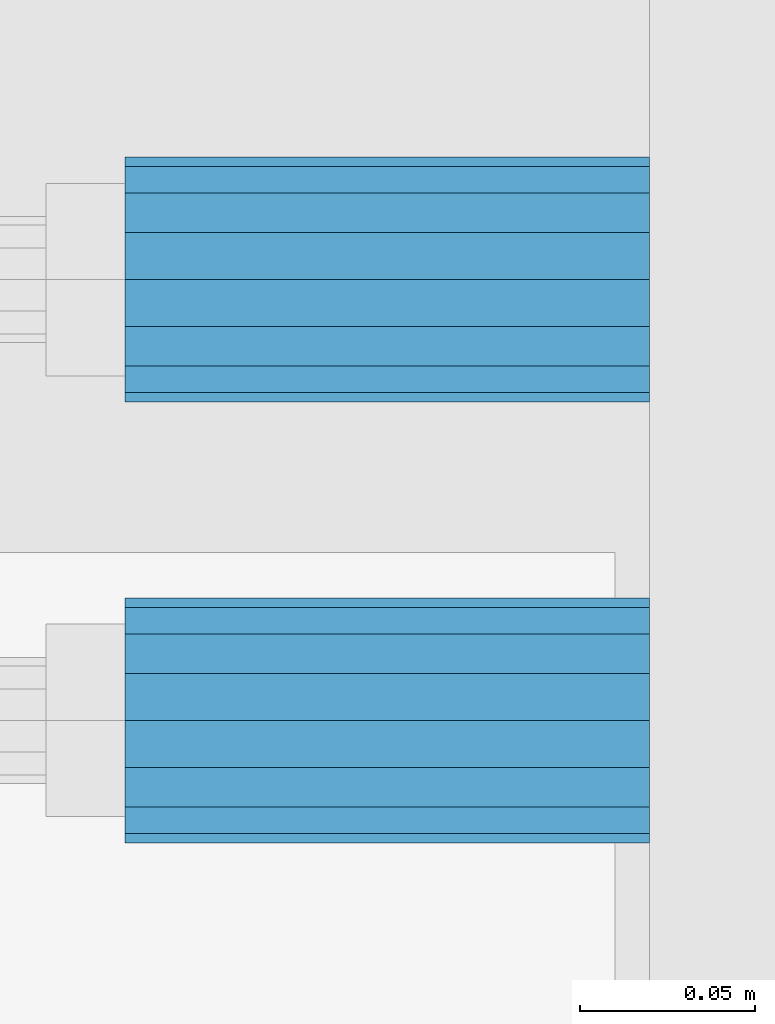
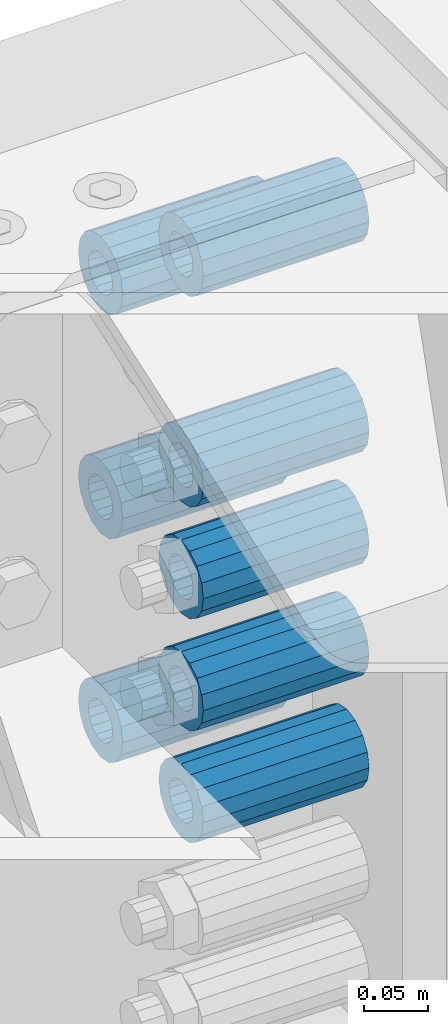
# One storey, part 171 of 242: 8 beams.
"""IFC2X3 building model written with IfcOpenShell, lengths in millimetres."""

import ifcopenshell
import ifcopenshell.guid

model = None  # the IFC model being written
_history = None  # IfcOwnerHistory: only IFC2X3 demands one
_inside = {}  # id of a spatial element -> (the spatial element, [elements in it])
_under = {}  # id of a project, library or spatial element -> (it, [spatial elements below it])
_declared = {}  # id of a project -> (the project, [libraries it declares])
_typed = {}  # id of a type object -> (the type object, [elements of that type])
_made_of = {}  # id of a material, layer set ... -> (it, [elements and type objects made of it])


def new_model(schema):
    """Start an empty IFC model of exactly this schema.

    Asked for "IFC4X3", IfcOpenShell would pick the latest addendum, in which some entities
    have other attributes; the version numbers below select the first issue.
    IFC2X3 requires an IfcOwnerHistory on every rooted entity: one is made here for all.
    """
    global model, _history
    if schema == "IFC4X3":
        model = ifcopenshell.file(schema_version=(4, 3, 0, 0))
    else:
        model = ifcopenshell.file(schema=schema)
    _inside.clear()
    _under.clear()
    _declared.clear()
    _typed.clear()
    _made_of.clear()
    _history = None
    if model.schema == "IFC2X3":
        org = make("IfcOrganization", Name="unknown")
        user = make(
            "IfcPersonAndOrganization",
            ThePerson=make("IfcPerson", FamilyName="unknown"),
            TheOrganization=org,
        )
        app = make(
            "IfcApplication",
            ApplicationDeveloper=org,
            Version="unknown",
            ApplicationFullName="unknown",
            ApplicationIdentifier="unknown",
        )
        _history = make(
            "IfcOwnerHistory",
            OwningUser=user,
            OwningApplication=app,
            ChangeAction="ADDED",
            CreationDate=0,
        )
    return model


def make(cls, **values):
    """One entity of the class cls with the attributes given. An attribute that is None is left unset."""
    return model.create_entity(
        cls, **{name: value for name, value in values.items() if value is not None}
    )


def rooted(cls, **values):
    """An entity with a GlobalId (a new one), such as an element, a storey or a relation."""
    return make(cls, GlobalId=ifcopenshell.guid.new(), OwnerHistory=_history, **values)


def si_unit(unit_type, name, prefix=None):
    """IfcSIUnit, for example si_unit("LENGTHUNIT", "METRE", prefix="MILLI")."""
    return make("IfcSIUnit", UnitType=unit_type, Prefix=prefix, Name=name)


def assignment(units):
    """IfcUnitAssignment: the units of a project."""
    return None if units is None else make("IfcUnitAssignment", Units=units)


def point(xyz):
    """IfcCartesianPoint."""
    return None if xyz is None else make("IfcCartesianPoint", Coordinates=xyz)


def direction(xyz):
    """IfcDirection."""
    return None if xyz is None else make("IfcDirection", DirectionRatios=xyz)


def frame(location, z_axis=None, x_axis=None):
    """IfcAxis2Placement3D, a coordinate frame: its origin and axes. An axis left out is left unset."""
    return make(
        "IfcAxis2Placement3D",
        Location=point(location),
        Axis=direction(z_axis),
        RefDirection=direction(x_axis),
    )


def origin_with_axes():
    """The frame at (0, 0, 0) with the z axis (0, 0, 1) and the x axis (1, 0, 0) written out."""
    return frame((0.0, 0.0, 0.0), z_axis=(0.0, 0.0, 1.0), x_axis=(1.0, 0.0, 0.0))


def place(relative_to, where):
    """IfcLocalPlacement: puts the frame where relative to a parent placement (None: the world)."""
    return make(
        "IfcLocalPlacement", PlacementRelTo=relative_to, RelativePlacement=where
    )


def context(
    kind, dimensions, precision=None, world=None, true_north=None, identifier=None
):
    """IfcGeometricRepresentationContext, for example the 3D "Model" context."""
    return make(
        "IfcGeometricRepresentationContext",
        ContextIdentifier=identifier,
        ContextType=kind,
        CoordinateSpaceDimension=dimensions,
        Precision=precision,
        WorldCoordinateSystem=world,
        TrueNorth=true_north,
    )


def subcontext(parent, identifier, kind, view, scale=None):
    """IfcGeometricRepresentationSubContext, for example "Body" below "Model"."""
    return make(
        "IfcGeometricRepresentationSubContext",
        ContextIdentifier=identifier,
        ContextType=kind,
        ParentContext=parent,
        TargetScale=scale,
        TargetView=view,
    )


def project(units=None, contexts=None):
    """IfcProject with its units and contexts."""
    return rooted(
        "IfcProject",
        Name="project",
        RepresentationContexts=contexts,
        UnitsInContext=assignment(units),
    )


def spatial(cls, under=None, at=None, **own):
    """A site, building, storey or space (cls), placed at a placement, below another one or the project."""
    s = rooted(cls, ObjectPlacement=at, **own)
    if under is not None:
        _under.setdefault(under.id(), (under, []))[1].append(s)
    return s


def faces_of(points, faces, orient=None, outer=None):
    """IfcFace entities. A face is a list of loops; a loop is a list of indices into points, from 0.

    orient and outer hold one flag for each loop. By default every Orientation is true, the
    first loop of a face is its IfcFaceOuterBound and the others are IfcFaceBound.
    """
    made = []
    for i, loops in enumerate(faces):
        bounds = []
        for j, loop in enumerate(loops):
            is_outer = j == 0 if outer is None else outer[i][j]
            bounds.append(
                make(
                    "IfcFaceOuterBound" if is_outer else "IfcFaceBound",
                    Bound=make("IfcPolyLoop", Polygon=[points[k] for k in loop]),
                    Orientation=True if orient is None else orient[i][j],
                )
            )
        made.append(make("IfcFace", Bounds=bounds))
    return made


def faceted_brep(points, faces, orient=None, outer=None, voids=None):
    """IfcFacetedBrep: a solid bounded by flat faces; with voids (closed shells), ...WithVoids."""
    shared = [point(p) for p in points]
    hull = make("IfcClosedShell", CfsFaces=faces_of(shared, faces, orient, outer))
    if voids is None:
        return make("IfcFacetedBrep", Outer=hull)
    return make(
        "IfcFacetedBrepWithVoids",
        Outer=hull,
        Voids=[
            make(cls, CfsFaces=faces_of(shared, fs, o, b)) for cls, fs, o, b in voids
        ],
    )


def shape(context_of_items, identifier, shape_type, items):
    """IfcShapeRepresentation: the items that make up one representation, for example the "Body"."""
    return make(
        "IfcShapeRepresentation",
        ContextOfItems=context_of_items,
        RepresentationIdentifier=identifier,
        RepresentationType=shape_type,
        Items=items,
    )


def material(Name=None, Category=None):
    """IfcMaterial."""
    return make("IfcMaterial", Name=Name, Category=Category)


def made_of(thing, what):
    """Note that an element or type object is made of a material, layer set ...; save() writes the relation."""
    if what is not None:
        _made_of.setdefault(what.id(), (what, []))[1].append(thing)
    return thing


def type_object(cls, material=None, **own):
    """A type object (cls), such as IfcWallType, which elements share."""
    return made_of(rooted(cls, **own), material)


def element(
    cls,
    number,
    at=None,
    inside=None,
    cuts=None,
    type_object=None,
    material=None,
    context=None,
    identifier="Body",
    shape_type=None,
    held_by="IfcProductDefinitionShape",
    body=None,
    shapes=None,
    **own,
):
    """One element of the class cls, such as IfcWall. Its Tag is "e" and its number.

    at: its placement. inside: the storey or other place that contains it. cuts: it is an
    opening in that element (IfcRelVoidsElement). A single representation is given by context,
    identifier, shape_type and body (its items); several are given by shapes. held_by: the class
    of the entity that holds the representations. save() writes the other relations.
    """
    e = rooted(cls, Tag="e%d" % number, ObjectPlacement=at, **own)
    if body is not None:
        shapes = [shape(context, identifier, shape_type, body)]
    if shapes is not None:
        e.Representation = make(held_by, Representations=shapes)
    if inside is not None:
        _inside.setdefault(inside.id(), (inside, []))[1].append(e)
    if cuts is not None:
        rooted(
            "IfcRelVoidsElement", RelatingBuildingElement=cuts, RelatedOpeningElement=e
        )
    if type_object is not None:
        _typed.setdefault(type_object.id(), (type_object, []))[1].append(e)
    return made_of(e, material)


def aggregate(whole, parts):
    """IfcRelAggregates: a whole, such as a stair, and the parts it consists of."""
    return rooted("IfcRelAggregates", RelatingObject=whole, RelatedObjects=parts)


def save(model, path):
    """Write the relations noted so far, then the file.

    IfcRelAggregates (storeys below a building ...), IfcRelContainedInSpatialStructure (elements
    in a storey), IfcRelDefinesByType, IfcRelAssociatesMaterial and IfcRelDeclares: one each for
    every whole, place, type object, material and project.
    """
    for whole, parts in _under.values():
        aggregate(whole, parts)
    for where, things in _inside.values():
        rooted(
            "IfcRelContainedInSpatialStructure",
            RelatedElements=things,
            RelatingStructure=where,
        )
    for kind, things in _typed.values():
        rooted("IfcRelDefinesByType", RelatedObjects=things, RelatingType=kind)
    for what, things in _made_of.values():
        rooted("IfcRelAssociatesMaterial", RelatedObjects=things, RelatingMaterial=what)
    for by, libraries in _declared.values():
        rooted("IfcRelDeclares", RelatingContext=by, RelatedDefinitions=libraries)
    model.write(path)


model = new_model("IFC2X3")

# Units and contexts
model_context = context("Model", 3, precision=1e-05, world=origin_with_axes())
body_context = subcontext(model_context, "Body", "Model", "MODEL_VIEW")
ifc_project = project(units=[si_unit("LENGTHUNIT", "METRE", prefix="MILLI"), si_unit("AREAUNIT", "SQUARE_METRE"), si_unit("VOLUMEUNIT", "CUBIC_METRE"), si_unit("MASSUNIT", "GRAM", prefix="KILO"), si_unit("TIMEUNIT", "SECOND"), si_unit("PLANEANGLEUNIT", "RADIAN"), si_unit("SOLIDANGLEUNIT", "STERADIAN"), si_unit("THERMODYNAMICTEMPERATUREUNIT", "DEGREE_CELSIUS"), si_unit("LUMINOUSINTENSITYUNIT", "LUMEN")], contexts=[model_context])

# Site, building, storey
site_placement = place(None, origin_with_axes())
site = spatial("IfcSite", under=ifc_project, at=site_placement, CompositionType="ELEMENT")
building_placement = place(site_placement, origin_with_axes())
building = spatial("IfcBuilding", under=site, at=building_placement, Name="Standard", CompositionType="ELEMENT")
storey_placement = place(building_placement, origin_with_axes())
storey = spatial("IfcBuildingStorey", under=building, at=storey_placement, Name="Undefined", CompositionType="ELEMENT", Elevation=0.0)

# Beams
ifc_material = material()
beam_type = type_object("IfcBeamType", PredefinedType="NOTDEFINED")
beam_1_placement = place(storey_placement, frame((-22210.0, -18063.0, -397.0), z_axis=(0.0, 0.0, 1.0), x_axis=(1.0, 0.0, 0.0)))
element("IfcBeam", 1, at=beam_1_placement, inside=storey, type_object=beam_type, material=ifc_material, context=body_context, shape_type="Brep", body=[
    faceted_brep([(1.33248249767348e-07, -19.0000000004493, -6.26823748461902e-09), (0.0, -17.5537111177146, 7.27098521493673), (150.0, -17.5537111177146, 7.27098521493673), (150.0, -19.0, 0.0), (0.0, -13.4350288425449, 13.4350288425444), (150.0, -13.4350288425449, 13.4350288425444), (0.0, -7.27098521493826, 17.5537111177144), (150.0, -7.27098521493826, 17.5537111177144), (-6.29370333626866e-09, -4.49290382675827e-10, 18.9999999937318), (150.0, 0.0, 19.0), (0.0, 7.27098521493826, 17.5537111177144), (150.0, 7.27098521493826, 17.5537111177144), (0.0, 13.4350288425449, 13.4350288425444), (150.0, 13.4350288425449, 13.4350288425444), (0.0, 17.5537111177146, 7.2709852149367), (150.0, 17.5537111177146, 7.2709852149367), (-1.31243723444641e-07, 18.9999999995507, -6.26823748461902e-09), (150.0, 19.0, 0.0), (0.0, 17.5537111177146, -7.2709852149367), (150.0, 17.5537111177146, -7.2709852149367), (0.0, 13.4350288425449, -13.4350288425444), (150.0, 13.4350288425449, -13.4350288425444), (0.0, 7.27098521493826, -17.5537111177144), (150.0, 7.27098521493826, -17.5537111177144), (8.2982296589762e-09, -4.49290382675827e-10, -19.0000000062719), (150.0, 0.0, -19.0), (0.0, -7.27098521493826, -17.5537111177144), (150.0, -7.27098521493826, -17.5537111177144), (0.0, -13.4350288425449, -13.4350288425444), (150.0, -13.4350288425449, -13.4350288425444), (0.0, -17.5537111177146, -7.2709852149367), (150.0, -17.5537111177146, -7.2709852149367), (-3.63797880709171e-12, -35.0, 0.0), (-3.63797880709171e-12, -32.335783637895, -13.3939201327812), (150.0, -32.3357836378964, -13.3939201327782), (150.0, -35.0, 0.0), (0.0, -24.7487373415292, -24.7487373415315), (150.0, -24.7487373415279, -24.7487373415292), (0.0, -13.3939201327782, -32.3357836378964), (150.0, -13.3939201327776, -32.335783637895), (0.0, 0.0, -35.0000000000036), (150.0, 0.0, -35.0), (0.0, 13.3939201327782, -32.3357836378964), (150.0, 13.3939201327776, -32.335783637895), (0.0, 24.7487373415292, -24.7487373415315), (150.0, 24.7487373415279, -24.7487373415292), (-3.63797880709171e-12, 32.335783637895, -13.3939201327812), (150.0, 32.3357836378964, -13.3939201327781), (-3.63797880709171e-12, 35.0, 0.0), (150.0, 35.0, 0.0), (-7.27595761418343e-12, 32.335783637895, 13.3939201327739), (150.0, 32.3357836378964, 13.3939201327781), (-7.27595761418343e-12, 24.7487373415292, 24.7487373415242), (150.0, 24.7487373415279, 24.7487373415292), (-7.27595761418343e-12, 13.3939201327781, 32.3357836378891), (150.0, 13.3939201327776, 32.335783637895), (-1.09139364212751e-11, 0.0, 34.9999999999964), (150.0, 0.0, 35.0), (-7.27595761418343e-12, -13.3939201327781, 32.3357836378891), (150.0, -13.3939201327776, 32.335783637895), (-7.27595761418343e-12, -24.7487373415292, 24.7487373415242), (150.0, -24.7487373415279, 24.7487373415292), (-7.27595761418343e-12, -32.335783637895, 13.3939201327739), (150.0, -32.3357836378964, 13.3939201327781)], [[[0, 1, 2, 3]], [[1, 4, 5, 2]], [[4, 6, 7, 5]], [[6, 8, 9, 7]], [[8, 10, 11, 9]], [[10, 12, 13, 11]], [[12, 14, 15, 13]], [[14, 16, 17, 15]], [[16, 18, 19, 17]], [[18, 20, 21, 19]], [[20, 22, 23, 21]], [[22, 24, 25, 23]], [[24, 26, 27, 25]], [[26, 28, 29, 27]], [[28, 30, 31, 29]], [[30, 0, 3, 31]], [[32, 33, 34, 35]], [[33, 36, 37, 34]], [[36, 38, 39, 37]], [[38, 40, 41, 39]], [[40, 42, 43, 41]], [[42, 44, 45, 43]], [[44, 46, 47, 45]], [[46, 48, 49, 47]], [[48, 50, 51, 49]], [[50, 52, 53, 51]], [[52, 54, 55, 53]], [[54, 56, 57, 55]], [[56, 58, 59, 57]], [[58, 60, 61, 59]], [[60, 62, 63, 61]], [[62, 32, 35, 63]], [[37, 39, 41, 43, 45, 47, 49, 51, 53, 55, 57, 59, 61, 63, 35, 34], [5, 7, 9, 11, 13, 15, 17, 19, 21, 23, 25, 27, 29, 31, 3, 2]], [[62, 60, 58, 56, 54, 52, 50, 48, 46, 44, 42, 40, 38, 36, 33, 32], [30, 28, 26, 24, 22, 20, 18, 16, 14, 12, 10, 8, 6, 4, 1, 0]]]),
])
beam_2_placement = place(storey_placement, frame((-22210.0, -17937.0, -611.0), z_axis=(0.0, 0.0, 1.0), x_axis=(1.0, 0.0, 0.0)))
element("IfcBeam", 2, at=beam_2_placement, inside=storey, type_object=beam_type, material=ifc_material, context=body_context, shape_type="Brep", body=[
    faceted_brep([(1.33248249767348e-07, -19.0000000004493, -6.26823748461902e-09), (0.0, -17.5537111177146, 7.27098521493673), (150.0, -17.5537111177146, 7.27098521493673), (150.0, -19.0, 0.0), (0.0, -13.4350288425449, 13.4350288425444), (150.0, -13.4350288425449, 13.4350288425444), (0.0, -7.27098521493826, 17.5537111177144), (150.0, -7.27098521493826, 17.5537111177144), (-6.29370333626866e-09, -4.49290382675827e-10, 18.9999999937318), (150.0, 0.0, 19.0), (0.0, 7.27098521493826, 17.5537111177144), (150.0, 7.27098521493826, 17.5537111177144), (0.0, 13.4350288425449, 13.4350288425444), (150.0, 13.4350288425449, 13.4350288425444), (0.0, 17.5537111177146, 7.2709852149367), (150.0, 17.5537111177146, 7.2709852149367), (-1.31243723444641e-07, 18.9999999995507, -6.26823748461902e-09), (150.0, 19.0, 0.0), (0.0, 17.5537111177146, -7.2709852149367), (150.0, 17.5537111177146, -7.2709852149367), (0.0, 13.4350288425449, -13.4350288425444), (150.0, 13.4350288425449, -13.4350288425444), (0.0, 7.27098521493826, -17.5537111177144), (150.0, 7.27098521493826, -17.5537111177144), (8.2982296589762e-09, -4.49290382675827e-10, -19.0000000062719), (150.0, 0.0, -19.0), (0.0, -7.27098521493826, -17.5537111177144), (150.0, -7.27098521493826, -17.5537111177144), (0.0, -13.4350288425449, -13.4350288425444), (150.0, -13.4350288425449, -13.4350288425444), (0.0, -17.5537111177146, -7.2709852149367), (150.0, -17.5537111177146, -7.2709852149367), (-3.63797880709171e-12, -35.0, 0.0), (-3.63797880709171e-12, -32.335783637895, -13.3939201327812), (150.0, -32.3357836378964, -13.3939201327782), (150.0, -35.0, 0.0), (0.0, -24.7487373415292, -24.7487373415315), (150.0, -24.7487373415279, -24.7487373415292), (0.0, -13.3939201327782, -32.3357836378964), (150.0, -13.3939201327776, -32.335783637895), (0.0, 0.0, -35.0000000000036), (150.0, 0.0, -35.0), (0.0, 13.3939201327782, -32.3357836378964), (150.0, 13.3939201327776, -32.335783637895), (0.0, 24.7487373415292, -24.7487373415315), (150.0, 24.7487373415279, -24.7487373415292), (-3.63797880709171e-12, 32.335783637895, -13.3939201327812), (150.0, 32.3357836378964, -13.3939201327781), (-3.63797880709171e-12, 35.0, 0.0), (150.0, 35.0, 0.0), (-7.27595761418343e-12, 32.335783637895, 13.3939201327739), (150.0, 32.3357836378964, 13.3939201327781), (-7.27595761418343e-12, 24.7487373415292, 24.7487373415242), (150.0, 24.7487373415279, 24.7487373415292), (-7.27595761418343e-12, 13.3939201327781, 32.3357836378891), (150.0, 13.3939201327776, 32.335783637895), (-1.09139364212751e-11, 0.0, 34.9999999999964), (150.0, 0.0, 35.0), (-7.27595761418343e-12, -13.3939201327781, 32.3357836378891), (150.0, -13.3939201327776, 32.335783637895), (-7.27595761418343e-12, -24.7487373415292, 24.7487373415242), (150.0, -24.7487373415279, 24.7487373415292), (-7.27595761418343e-12, -32.335783637895, 13.3939201327739), (150.0, -32.3357836378964, 13.3939201327781)], [[[0, 1, 2, 3]], [[1, 4, 5, 2]], [[4, 6, 7, 5]], [[6, 8, 9, 7]], [[8, 10, 11, 9]], [[10, 12, 13, 11]], [[12, 14, 15, 13]], [[14, 16, 17, 15]], [[16, 18, 19, 17]], [[18, 20, 21, 19]], [[20, 22, 23, 21]], [[22, 24, 25, 23]], [[24, 26, 27, 25]], [[26, 28, 29, 27]], [[28, 30, 31, 29]], [[30, 0, 3, 31]], [[32, 33, 34, 35]], [[33, 36, 37, 34]], [[36, 38, 39, 37]], [[38, 40, 41, 39]], [[40, 42, 43, 41]], [[42, 44, 45, 43]], [[44, 46, 47, 45]], [[46, 48, 49, 47]], [[48, 50, 51, 49]], [[50, 52, 53, 51]], [[52, 54, 55, 53]], [[54, 56, 57, 55]], [[56, 58, 59, 57]], [[58, 60, 61, 59]], [[60, 62, 63, 61]], [[62, 32, 35, 63]], [[37, 39, 41, 43, 45, 47, 49, 51, 53, 55, 57, 59, 61, 63, 35, 34], [5, 7, 9, 11, 13, 15, 17, 19, 21, 23, 25, 27, 29, 31, 3, 2]], [[62, 60, 58, 56, 54, 52, 50, 48, 46, 44, 42, 40, 38, 36, 33, 32], [30, 28, 26, 24, 22, 20, 18, 16, 14, 12, 10, 8, 6, 4, 1, 0]]]),
])
beam_3_placement = place(storey_placement, frame((-22210.0, -18063.0, -290.0), z_axis=(0.0, 0.0, 1.0), x_axis=(1.0, 0.0, 0.0)))
element("IfcBeam", 3, at=beam_3_placement, inside=storey, type_object=beam_type, material=ifc_material, context=body_context, shape_type="Brep", body=[
    faceted_brep([(1.33248249767348e-07, -19.0000000004493, -6.26823748461902e-09), (0.0, -17.5537111177146, 7.27098521493673), (150.0, -17.5537111177146, 7.27098521493673), (150.0, -19.0, 0.0), (0.0, -13.4350288425449, 13.4350288425444), (150.0, -13.4350288425449, 13.4350288425444), (0.0, -7.27098521493826, 17.5537111177144), (150.0, -7.27098521493826, 17.5537111177144), (-6.29370333626866e-09, -4.49290382675827e-10, 18.9999999937318), (150.0, 0.0, 19.0), (0.0, 7.27098521493826, 17.5537111177144), (150.0, 7.27098521493826, 17.5537111177144), (0.0, 13.4350288425449, 13.4350288425444), (150.0, 13.4350288425449, 13.4350288425444), (0.0, 17.5537111177146, 7.2709852149367), (150.0, 17.5537111177146, 7.2709852149367), (-1.31243723444641e-07, 18.9999999995507, -6.26823748461902e-09), (150.0, 19.0, 0.0), (0.0, 17.5537111177146, -7.2709852149367), (150.0, 17.5537111177146, -7.2709852149367), (0.0, 13.4350288425449, -13.4350288425444), (150.0, 13.4350288425449, -13.4350288425444), (0.0, 7.27098521493826, -17.5537111177144), (150.0, 7.27098521493826, -17.5537111177144), (8.2982296589762e-09, -4.49290382675827e-10, -19.0000000062719), (150.0, 0.0, -19.0), (0.0, -7.27098521493826, -17.5537111177144), (150.0, -7.27098521493826, -17.5537111177144), (0.0, -13.4350288425449, -13.4350288425444), (150.0, -13.4350288425449, -13.4350288425444), (0.0, -17.5537111177146, -7.2709852149367), (150.0, -17.5537111177146, -7.2709852149367), (-3.63797880709171e-12, -35.0, 0.0), (-3.63797880709171e-12, -32.335783637895, -13.3939201327812), (150.0, -32.3357836378964, -13.3939201327782), (150.0, -35.0, 0.0), (0.0, -24.7487373415292, -24.7487373415315), (150.0, -24.7487373415279, -24.7487373415292), (0.0, -13.3939201327782, -32.3357836378964), (150.0, -13.3939201327776, -32.335783637895), (0.0, 0.0, -35.0000000000036), (150.0, 0.0, -35.0), (0.0, 13.3939201327782, -32.3357836378964), (150.0, 13.3939201327776, -32.335783637895), (0.0, 24.7487373415292, -24.7487373415315), (150.0, 24.7487373415279, -24.7487373415292), (-3.63797880709171e-12, 32.335783637895, -13.3939201327812), (150.0, 32.3357836378964, -13.3939201327781), (-3.63797880709171e-12, 35.0, 0.0), (150.0, 35.0, 0.0), (-7.27595761418343e-12, 32.335783637895, 13.3939201327739), (150.0, 32.3357836378964, 13.3939201327781), (-7.27595761418343e-12, 24.7487373415292, 24.7487373415242), (150.0, 24.7487373415279, 24.7487373415292), (-7.27595761418343e-12, 13.3939201327781, 32.3357836378891), (150.0, 13.3939201327776, 32.335783637895), (-1.09139364212751e-11, 0.0, 34.9999999999964), (150.0, 0.0, 35.0), (-7.27595761418343e-12, -13.3939201327781, 32.3357836378891), (150.0, -13.3939201327776, 32.335783637895), (-7.27595761418343e-12, -24.7487373415292, 24.7487373415242), (150.0, -24.7487373415279, 24.7487373415292), (-7.27595761418343e-12, -32.335783637895, 13.3939201327739), (150.0, -32.3357836378964, 13.3939201327781)], [[[0, 1, 2, 3]], [[1, 4, 5, 2]], [[4, 6, 7, 5]], [[6, 8, 9, 7]], [[8, 10, 11, 9]], [[10, 12, 13, 11]], [[12, 14, 15, 13]], [[14, 16, 17, 15]], [[16, 18, 19, 17]], [[18, 20, 21, 19]], [[20, 22, 23, 21]], [[22, 24, 25, 23]], [[24, 26, 27, 25]], [[26, 28, 29, 27]], [[28, 30, 31, 29]], [[30, 0, 3, 31]], [[32, 33, 34, 35]], [[33, 36, 37, 34]], [[36, 38, 39, 37]], [[38, 40, 41, 39]], [[40, 42, 43, 41]], [[42, 44, 45, 43]], [[44, 46, 47, 45]], [[46, 48, 49, 47]], [[48, 50, 51, 49]], [[50, 52, 53, 51]], [[52, 54, 55, 53]], [[54, 56, 57, 55]], [[56, 58, 59, 57]], [[58, 60, 61, 59]], [[60, 62, 63, 61]], [[62, 32, 35, 63]], [[37, 39, 41, 43, 45, 47, 49, 51, 53, 55, 57, 59, 61, 63, 35, 34], [5, 7, 9, 11, 13, 15, 17, 19, 21, 23, 25, 27, 29, 31, 3, 2]], [[62, 60, 58, 56, 54, 52, 50, 48, 46, 44, 42, 40, 38, 36, 33, 32], [30, 28, 26, 24, 22, 20, 18, 16, 14, 12, 10, 8, 6, 4, 1, 0]]]),
])
beam_4_placement = place(storey_placement, frame((-22210.0, -17937.0, -183.0), z_axis=(0.0, 0.0, 1.0), x_axis=(1.0, 0.0, 0.0)))
element("IfcBeam", 4, at=beam_4_placement, inside=storey, type_object=beam_type, material=ifc_material, context=body_context, shape_type="Brep", body=[
    faceted_brep([(1.33248249767348e-07, -19.0000000004493, -6.26823748461902e-09), (0.0, -17.5537111177146, 7.27098521493673), (150.0, -17.5537111177146, 7.27098521493673), (150.0, -19.0, 0.0), (0.0, -13.4350288425449, 13.4350288425444), (150.0, -13.4350288425449, 13.4350288425444), (0.0, -7.27098521493826, 17.5537111177144), (150.0, -7.27098521493826, 17.5537111177144), (-6.29370333626866e-09, -4.49290382675827e-10, 18.9999999937318), (150.0, 0.0, 19.0), (0.0, 7.27098521493826, 17.5537111177144), (150.0, 7.27098521493826, 17.5537111177144), (0.0, 13.4350288425449, 13.4350288425444), (150.0, 13.4350288425449, 13.4350288425444), (0.0, 17.5537111177146, 7.2709852149367), (150.0, 17.5537111177146, 7.2709852149367), (-1.31243723444641e-07, 18.9999999995507, -6.26823748461902e-09), (150.0, 19.0, 0.0), (0.0, 17.5537111177146, -7.2709852149367), (150.0, 17.5537111177146, -7.2709852149367), (0.0, 13.4350288425449, -13.4350288425444), (150.0, 13.4350288425449, -13.4350288425444), (0.0, 7.27098521493826, -17.5537111177144), (150.0, 7.27098521493826, -17.5537111177144), (8.2982296589762e-09, -4.49290382675827e-10, -19.0000000062719), (150.0, 0.0, -19.0), (0.0, -7.27098521493826, -17.5537111177144), (150.0, -7.27098521493826, -17.5537111177144), (0.0, -13.4350288425449, -13.4350288425444), (150.0, -13.4350288425449, -13.4350288425444), (0.0, -17.5537111177146, -7.2709852149367), (150.0, -17.5537111177146, -7.2709852149367), (-3.63797880709171e-12, -35.0, 0.0), (-3.63797880709171e-12, -32.335783637895, -13.3939201327812), (150.0, -32.3357836378964, -13.3939201327782), (150.0, -35.0, 0.0), (0.0, -24.7487373415292, -24.7487373415315), (150.0, -24.7487373415279, -24.7487373415292), (0.0, -13.3939201327782, -32.3357836378964), (150.0, -13.3939201327776, -32.335783637895), (0.0, 0.0, -35.0000000000036), (150.0, 0.0, -35.0), (0.0, 13.3939201327782, -32.3357836378964), (150.0, 13.3939201327776, -32.335783637895), (0.0, 24.7487373415292, -24.7487373415315), (150.0, 24.7487373415279, -24.7487373415292), (-3.63797880709171e-12, 32.335783637895, -13.3939201327812), (150.0, 32.3357836378964, -13.3939201327781), (-3.63797880709171e-12, 35.0, 0.0), (150.0, 35.0, 0.0), (-7.27595761418343e-12, 32.335783637895, 13.3939201327739), (150.0, 32.3357836378964, 13.3939201327781), (-7.27595761418343e-12, 24.7487373415292, 24.7487373415242), (150.0, 24.7487373415279, 24.7487373415292), (-7.27595761418343e-12, 13.3939201327781, 32.3357836378891), (150.0, 13.3939201327776, 32.335783637895), (-1.09139364212751e-11, 0.0, 34.9999999999964), (150.0, 0.0, 35.0), (-7.27595761418343e-12, -13.3939201327781, 32.3357836378891), (150.0, -13.3939201327776, 32.335783637895), (-7.27595761418343e-12, -24.7487373415292, 24.7487373415242), (150.0, -24.7487373415279, 24.7487373415292), (-7.27595761418343e-12, -32.335783637895, 13.3939201327739), (150.0, -32.3357836378964, 13.3939201327781)], [[[0, 1, 2, 3]], [[1, 4, 5, 2]], [[4, 6, 7, 5]], [[6, 8, 9, 7]], [[8, 10, 11, 9]], [[10, 12, 13, 11]], [[12, 14, 15, 13]], [[14, 16, 17, 15]], [[16, 18, 19, 17]], [[18, 20, 21, 19]], [[20, 22, 23, 21]], [[22, 24, 25, 23]], [[24, 26, 27, 25]], [[26, 28, 29, 27]], [[28, 30, 31, 29]], [[30, 0, 3, 31]], [[32, 33, 34, 35]], [[33, 36, 37, 34]], [[36, 38, 39, 37]], [[38, 40, 41, 39]], [[40, 42, 43, 41]], [[42, 44, 45, 43]], [[44, 46, 47, 45]], [[46, 48, 49, 47]], [[48, 50, 51, 49]], [[50, 52, 53, 51]], [[52, 54, 55, 53]], [[54, 56, 57, 55]], [[56, 58, 59, 57]], [[58, 60, 61, 59]], [[60, 62, 63, 61]], [[62, 32, 35, 63]], [[37, 39, 41, 43, 45, 47, 49, 51, 53, 55, 57, 59, 61, 63, 35, 34], [5, 7, 9, 11, 13, 15, 17, 19, 21, 23, 25, 27, 29, 31, 3, 2]], [[62, 60, 58, 56, 54, 52, 50, 48, 46, 44, 42, 40, 38, 36, 33, 32], [30, 28, 26, 24, 22, 20, 18, 16, 14, 12, 10, 8, 6, 4, 1, 0]]]),
])
beam_5_placement = place(storey_placement, frame((-22210.0, -18063.0, -504.0), z_axis=(0.0, 0.0, 1.0), x_axis=(1.0, 0.0, 0.0)))
element("IfcBeam", 5, at=beam_5_placement, inside=storey, type_object=beam_type, material=ifc_material, context=body_context, shape_type="Brep", body=[
    faceted_brep([(1.33248249767348e-07, -19.0000000004493, -6.26823748461902e-09), (0.0, -17.5537111177146, 7.27098521493673), (150.0, -17.5537111177146, 7.27098521493673), (150.0, -19.0, 0.0), (0.0, -13.4350288425449, 13.4350288425444), (150.0, -13.4350288425449, 13.4350288425444), (0.0, -7.27098521493826, 17.5537111177144), (150.0, -7.27098521493826, 17.5537111177144), (-6.29370333626866e-09, -4.49290382675827e-10, 18.9999999937318), (150.0, 0.0, 19.0), (0.0, 7.27098521493826, 17.5537111177144), (150.0, 7.27098521493826, 17.5537111177144), (0.0, 13.4350288425449, 13.4350288425444), (150.0, 13.4350288425449, 13.4350288425444), (0.0, 17.5537111177146, 7.2709852149367), (150.0, 17.5537111177146, 7.2709852149367), (-1.31243723444641e-07, 18.9999999995507, -6.26823748461902e-09), (150.0, 19.0, 0.0), (0.0, 17.5537111177146, -7.2709852149367), (150.0, 17.5537111177146, -7.2709852149367), (0.0, 13.4350288425449, -13.4350288425444), (150.0, 13.4350288425449, -13.4350288425444), (0.0, 7.27098521493826, -17.5537111177144), (150.0, 7.27098521493826, -17.5537111177144), (8.2982296589762e-09, -4.49290382675827e-10, -19.0000000062719), (150.0, 0.0, -19.0), (0.0, -7.27098521493826, -17.5537111177144), (150.0, -7.27098521493826, -17.5537111177144), (0.0, -13.4350288425449, -13.4350288425444), (150.0, -13.4350288425449, -13.4350288425444), (0.0, -17.5537111177146, -7.2709852149367), (150.0, -17.5537111177146, -7.2709852149367), (-3.63797880709171e-12, -35.0, 0.0), (-3.63797880709171e-12, -32.335783637895, -13.3939201327812), (150.0, -32.3357836378964, -13.3939201327782), (150.0, -35.0, 0.0), (0.0, -24.7487373415292, -24.7487373415315), (150.0, -24.7487373415279, -24.7487373415292), (0.0, -13.3939201327782, -32.3357836378964), (150.0, -13.3939201327776, -32.335783637895), (0.0, 0.0, -35.0000000000036), (150.0, 0.0, -35.0), (0.0, 13.3939201327782, -32.3357836378964), (150.0, 13.3939201327776, -32.335783637895), (0.0, 24.7487373415292, -24.7487373415315), (150.0, 24.7487373415279, -24.7487373415292), (-3.63797880709171e-12, 32.335783637895, -13.3939201327812), (150.0, 32.3357836378964, -13.3939201327781), (-3.63797880709171e-12, 35.0, 0.0), (150.0, 35.0, 0.0), (-7.27595761418343e-12, 32.335783637895, 13.3939201327739), (150.0, 32.3357836378964, 13.3939201327781), (-7.27595761418343e-12, 24.7487373415292, 24.7487373415242), (150.0, 24.7487373415279, 24.7487373415292), (-7.27595761418343e-12, 13.3939201327781, 32.3357836378891), (150.0, 13.3939201327776, 32.335783637895), (-1.09139364212751e-11, 0.0, 34.9999999999964), (150.0, 0.0, 35.0), (-7.27595761418343e-12, -13.3939201327781, 32.3357836378891), (150.0, -13.3939201327776, 32.335783637895), (-7.27595761418343e-12, -24.7487373415292, 24.7487373415242), (150.0, -24.7487373415279, 24.7487373415292), (-7.27595761418343e-12, -32.335783637895, 13.3939201327739), (150.0, -32.3357836378964, 13.3939201327781)], [[[0, 1, 2, 3]], [[1, 4, 5, 2]], [[4, 6, 7, 5]], [[6, 8, 9, 7]], [[8, 10, 11, 9]], [[10, 12, 13, 11]], [[12, 14, 15, 13]], [[14, 16, 17, 15]], [[16, 18, 19, 17]], [[18, 20, 21, 19]], [[20, 22, 23, 21]], [[22, 24, 25, 23]], [[24, 26, 27, 25]], [[26, 28, 29, 27]], [[28, 30, 31, 29]], [[30, 0, 3, 31]], [[32, 33, 34, 35]], [[33, 36, 37, 34]], [[36, 38, 39, 37]], [[38, 40, 41, 39]], [[40, 42, 43, 41]], [[42, 44, 45, 43]], [[44, 46, 47, 45]], [[46, 48, 49, 47]], [[48, 50, 51, 49]], [[50, 52, 53, 51]], [[52, 54, 55, 53]], [[54, 56, 57, 55]], [[56, 58, 59, 57]], [[58, 60, 61, 59]], [[60, 62, 63, 61]], [[62, 32, 35, 63]], [[37, 39, 41, 43, 45, 47, 49, 51, 53, 55, 57, 59, 61, 63, 35, 34], [5, 7, 9, 11, 13, 15, 17, 19, 21, 23, 25, 27, 29, 31, 3, 2]], [[62, 60, 58, 56, 54, 52, 50, 48, 46, 44, 42, 40, 38, 36, 33, 32], [30, 28, 26, 24, 22, 20, 18, 16, 14, 12, 10, 8, 6, 4, 1, 0]]]),
])
beam_6_placement = place(storey_placement, frame((-22210.0, -18063.0, -611.0), z_axis=(0.0, 0.0, 1.0), x_axis=(1.0, 0.0, 0.0)))
element("IfcBeam", 6, at=beam_6_placement, inside=storey, type_object=beam_type, material=ifc_material, context=body_context, shape_type="Brep", body=[
    faceted_brep([(1.33248249767348e-07, -19.0000000004493, -6.26823748461902e-09), (0.0, -17.5537111177146, 7.27098521493673), (150.0, -17.5537111177146, 7.27098521493673), (150.0, -19.0, 0.0), (0.0, -13.4350288425449, 13.4350288425444), (150.0, -13.4350288425449, 13.4350288425444), (0.0, -7.27098521493826, 17.5537111177144), (150.0, -7.27098521493826, 17.5537111177144), (-6.29370333626866e-09, -4.49290382675827e-10, 18.9999999937318), (150.0, 0.0, 19.0), (0.0, 7.27098521493826, 17.5537111177144), (150.0, 7.27098521493826, 17.5537111177144), (0.0, 13.4350288425449, 13.4350288425444), (150.0, 13.4350288425449, 13.4350288425444), (0.0, 17.5537111177146, 7.2709852149367), (150.0, 17.5537111177146, 7.2709852149367), (-1.31243723444641e-07, 18.9999999995507, -6.26823748461902e-09), (150.0, 19.0, 0.0), (0.0, 17.5537111177146, -7.2709852149367), (150.0, 17.5537111177146, -7.2709852149367), (0.0, 13.4350288425449, -13.4350288425444), (150.0, 13.4350288425449, -13.4350288425444), (0.0, 7.27098521493826, -17.5537111177144), (150.0, 7.27098521493826, -17.5537111177144), (8.2982296589762e-09, -4.49290382675827e-10, -19.0000000062719), (150.0, 0.0, -19.0), (0.0, -7.27098521493826, -17.5537111177144), (150.0, -7.27098521493826, -17.5537111177144), (0.0, -13.4350288425449, -13.4350288425444), (150.0, -13.4350288425449, -13.4350288425444), (0.0, -17.5537111177146, -7.2709852149367), (150.0, -17.5537111177146, -7.2709852149367), (-3.63797880709171e-12, -35.0, 0.0), (-3.63797880709171e-12, -32.335783637895, -13.3939201327812), (150.0, -32.3357836378964, -13.3939201327782), (150.0, -35.0, 0.0), (0.0, -24.7487373415292, -24.7487373415315), (150.0, -24.7487373415279, -24.7487373415292), (0.0, -13.3939201327782, -32.3357836378964), (150.0, -13.3939201327776, -32.335783637895), (0.0, 0.0, -35.0000000000036), (150.0, 0.0, -35.0), (0.0, 13.3939201327782, -32.3357836378964), (150.0, 13.3939201327776, -32.335783637895), (0.0, 24.7487373415292, -24.7487373415315), (150.0, 24.7487373415279, -24.7487373415292), (-3.63797880709171e-12, 32.335783637895, -13.3939201327812), (150.0, 32.3357836378964, -13.3939201327781), (-3.63797880709171e-12, 35.0, 0.0), (150.0, 35.0, 0.0), (-7.27595761418343e-12, 32.335783637895, 13.3939201327739), (150.0, 32.3357836378964, 13.3939201327781), (-7.27595761418343e-12, 24.7487373415292, 24.7487373415242), (150.0, 24.7487373415279, 24.7487373415292), (-7.27595761418343e-12, 13.3939201327781, 32.3357836378891), (150.0, 13.3939201327776, 32.335783637895), (-1.09139364212751e-11, 0.0, 34.9999999999964), (150.0, 0.0, 35.0), (-7.27595761418343e-12, -13.3939201327781, 32.3357836378891), (150.0, -13.3939201327776, 32.335783637895), (-7.27595761418343e-12, -24.7487373415292, 24.7487373415242), (150.0, -24.7487373415279, 24.7487373415292), (-7.27595761418343e-12, -32.335783637895, 13.3939201327739), (150.0, -32.3357836378964, 13.3939201327781)], [[[0, 1, 2, 3]], [[1, 4, 5, 2]], [[4, 6, 7, 5]], [[6, 8, 9, 7]], [[8, 10, 11, 9]], [[10, 12, 13, 11]], [[12, 14, 15, 13]], [[14, 16, 17, 15]], [[16, 18, 19, 17]], [[18, 20, 21, 19]], [[20, 22, 23, 21]], [[22, 24, 25, 23]], [[24, 26, 27, 25]], [[26, 28, 29, 27]], [[28, 30, 31, 29]], [[30, 0, 3, 31]], [[32, 33, 34, 35]], [[33, 36, 37, 34]], [[36, 38, 39, 37]], [[38, 40, 41, 39]], [[40, 42, 43, 41]], [[42, 44, 45, 43]], [[44, 46, 47, 45]], [[46, 48, 49, 47]], [[48, 50, 51, 49]], [[50, 52, 53, 51]], [[52, 54, 55, 53]], [[54, 56, 57, 55]], [[56, 58, 59, 57]], [[58, 60, 61, 59]], [[60, 62, 63, 61]], [[62, 32, 35, 63]], [[37, 39, 41, 43, 45, 47, 49, 51, 53, 55, 57, 59, 61, 63, 35, 34], [5, 7, 9, 11, 13, 15, 17, 19, 21, 23, 25, 27, 29, 31, 3, 2]], [[62, 60, 58, 56, 54, 52, 50, 48, 46, 44, 42, 40, 38, 36, 33, 32], [30, 28, 26, 24, 22, 20, 18, 16, 14, 12, 10, 8, 6, 4, 1, 0]]]),
])
beam_7_placement = place(storey_placement, frame((-22210.0, -17937.0, -397.0), z_axis=(0.0, 0.0, 1.0), x_axis=(1.0, 0.0, 0.0)))
element("IfcBeam", 7, at=beam_7_placement, inside=storey, type_object=beam_type, material=ifc_material, context=body_context, shape_type="Brep", body=[
    faceted_brep([(1.33248249767348e-07, -19.0000000004493, -6.26823748461902e-09), (0.0, -17.5537111177146, 7.27098521493673), (150.0, -17.5537111177146, 7.27098521493673), (150.0, -19.0, 0.0), (0.0, -13.4350288425449, 13.4350288425444), (150.0, -13.4350288425449, 13.4350288425444), (0.0, -7.27098521493826, 17.5537111177144), (150.0, -7.27098521493826, 17.5537111177144), (-6.29370333626866e-09, -4.49290382675827e-10, 18.9999999937318), (150.0, 0.0, 19.0), (0.0, 7.27098521493826, 17.5537111177144), (150.0, 7.27098521493826, 17.5537111177144), (0.0, 13.4350288425449, 13.4350288425444), (150.0, 13.4350288425449, 13.4350288425444), (0.0, 17.5537111177146, 7.2709852149367), (150.0, 17.5537111177146, 7.2709852149367), (-1.31243723444641e-07, 18.9999999995507, -6.26823748461902e-09), (150.0, 19.0, 0.0), (0.0, 17.5537111177146, -7.2709852149367), (150.0, 17.5537111177146, -7.2709852149367), (0.0, 13.4350288425449, -13.4350288425444), (150.0, 13.4350288425449, -13.4350288425444), (0.0, 7.27098521493826, -17.5537111177144), (150.0, 7.27098521493826, -17.5537111177144), (8.2982296589762e-09, -4.49290382675827e-10, -19.0000000062719), (150.0, 0.0, -19.0), (0.0, -7.27098521493826, -17.5537111177144), (150.0, -7.27098521493826, -17.5537111177144), (0.0, -13.4350288425449, -13.4350288425444), (150.0, -13.4350288425449, -13.4350288425444), (0.0, -17.5537111177146, -7.2709852149367), (150.0, -17.5537111177146, -7.2709852149367), (-3.63797880709171e-12, -35.0, 0.0), (-3.63797880709171e-12, -32.335783637895, -13.3939201327812), (150.0, -32.3357836378964, -13.3939201327782), (150.0, -35.0, 0.0), (0.0, -24.7487373415292, -24.7487373415315), (150.0, -24.7487373415279, -24.7487373415292), (0.0, -13.3939201327782, -32.3357836378964), (150.0, -13.3939201327776, -32.335783637895), (0.0, 0.0, -35.0000000000036), (150.0, 0.0, -35.0), (0.0, 13.3939201327782, -32.3357836378964), (150.0, 13.3939201327776, -32.335783637895), (0.0, 24.7487373415292, -24.7487373415315), (150.0, 24.7487373415279, -24.7487373415292), (-3.63797880709171e-12, 32.335783637895, -13.3939201327812), (150.0, 32.3357836378964, -13.3939201327781), (-3.63797880709171e-12, 35.0, 0.0), (150.0, 35.0, 0.0), (-7.27595761418343e-12, 32.335783637895, 13.3939201327739), (150.0, 32.3357836378964, 13.3939201327781), (-7.27595761418343e-12, 24.7487373415292, 24.7487373415242), (150.0, 24.7487373415279, 24.7487373415292), (-7.27595761418343e-12, 13.3939201327781, 32.3357836378891), (150.0, 13.3939201327776, 32.335783637895), (-1.09139364212751e-11, 0.0, 34.9999999999964), (150.0, 0.0, 35.0), (-7.27595761418343e-12, -13.3939201327781, 32.3357836378891), (150.0, -13.3939201327776, 32.335783637895), (-7.27595761418343e-12, -24.7487373415292, 24.7487373415242), (150.0, -24.7487373415279, 24.7487373415292), (-7.27595761418343e-12, -32.335783637895, 13.3939201327739), (150.0, -32.3357836378964, 13.3939201327781)], [[[0, 1, 2, 3]], [[1, 4, 5, 2]], [[4, 6, 7, 5]], [[6, 8, 9, 7]], [[8, 10, 11, 9]], [[10, 12, 13, 11]], [[12, 14, 15, 13]], [[14, 16, 17, 15]], [[16, 18, 19, 17]], [[18, 20, 21, 19]], [[20, 22, 23, 21]], [[22, 24, 25, 23]], [[24, 26, 27, 25]], [[26, 28, 29, 27]], [[28, 30, 31, 29]], [[30, 0, 3, 31]], [[32, 33, 34, 35]], [[33, 36, 37, 34]], [[36, 38, 39, 37]], [[38, 40, 41, 39]], [[40, 42, 43, 41]], [[42, 44, 45, 43]], [[44, 46, 47, 45]], [[46, 48, 49, 47]], [[48, 50, 51, 49]], [[50, 52, 53, 51]], [[52, 54, 55, 53]], [[54, 56, 57, 55]], [[56, 58, 59, 57]], [[58, 60, 61, 59]], [[60, 62, 63, 61]], [[62, 32, 35, 63]], [[37, 39, 41, 43, 45, 47, 49, 51, 53, 55, 57, 59, 61, 63, 35, 34], [5, 7, 9, 11, 13, 15, 17, 19, 21, 23, 25, 27, 29, 31, 3, 2]], [[62, 60, 58, 56, 54, 52, 50, 48, 46, 44, 42, 40, 38, 36, 33, 32], [30, 28, 26, 24, 22, 20, 18, 16, 14, 12, 10, 8, 6, 4, 1, 0]]]),
])
beam_8_placement = place(storey_placement, frame((-22210.0, -18063.0, -89.0000000000001), z_axis=(0.0, 0.0, 1.0), x_axis=(1.0, 0.0, 0.0)))
element("IfcBeam", 8, at=beam_8_placement, inside=storey, type_object=beam_type, material=ifc_material, context=body_context, shape_type="Brep", body=[
    faceted_brep([(1.33248249767348e-07, -19.0000000004493, -6.26823748461902e-09), (0.0, -17.5537111177146, 7.27098521493673), (150.0, -17.5537111177146, 7.27098521493673), (150.0, -19.0, 0.0), (0.0, -13.4350288425449, 13.4350288425444), (150.0, -13.4350288425449, 13.4350288425444), (0.0, -7.27098521493826, 17.5537111177144), (150.0, -7.27098521493826, 17.5537111177144), (-6.29370333626866e-09, -4.49290382675827e-10, 18.9999999937318), (150.0, 0.0, 19.0), (0.0, 7.27098521493826, 17.5537111177144), (150.0, 7.27098521493826, 17.5537111177144), (0.0, 13.4350288425449, 13.4350288425444), (150.0, 13.4350288425449, 13.4350288425444), (0.0, 17.5537111177146, 7.2709852149367), (150.0, 17.5537111177146, 7.2709852149367), (-1.31243723444641e-07, 18.9999999995507, -6.26823748461902e-09), (150.0, 19.0, 0.0), (0.0, 17.5537111177146, -7.2709852149367), (150.0, 17.5537111177146, -7.2709852149367), (0.0, 13.4350288425449, -13.4350288425444), (150.0, 13.4350288425449, -13.4350288425444), (0.0, 7.27098521493826, -17.5537111177144), (150.0, 7.27098521493826, -17.5537111177144), (8.2982296589762e-09, -4.49290382675827e-10, -19.0000000062719), (150.0, 0.0, -19.0), (0.0, -7.27098521493826, -17.5537111177144), (150.0, -7.27098521493826, -17.5537111177144), (0.0, -13.4350288425449, -13.4350288425444), (150.0, -13.4350288425449, -13.4350288425444), (0.0, -17.5537111177146, -7.2709852149367), (150.0, -17.5537111177146, -7.2709852149367), (-3.63797880709171e-12, -35.0, 0.0), (-3.63797880709171e-12, -32.335783637895, -13.3939201327812), (150.0, -32.3357836378964, -13.3939201327782), (150.0, -35.0, 0.0), (0.0, -24.7487373415292, -24.7487373415315), (150.0, -24.7487373415279, -24.7487373415292), (0.0, -13.3939201327782, -32.3357836378964), (150.0, -13.3939201327776, -32.335783637895), (0.0, 0.0, -35.0000000000036), (150.0, 0.0, -35.0), (0.0, 13.3939201327782, -32.3357836378964), (150.0, 13.3939201327776, -32.335783637895), (0.0, 24.7487373415292, -24.7487373415315), (150.0, 24.7487373415279, -24.7487373415292), (-3.63797880709171e-12, 32.335783637895, -13.3939201327812), (150.0, 32.3357836378964, -13.3939201327781), (-3.63797880709171e-12, 35.0, 0.0), (150.0, 35.0, 0.0), (-7.27595761418343e-12, 32.335783637895, 13.3939201327739), (150.0, 32.3357836378964, 13.3939201327781), (-7.27595761418343e-12, 24.7487373415292, 24.7487373415242), (150.0, 24.7487373415279, 24.7487373415292), (-7.27595761418343e-12, 13.3939201327781, 32.3357836378891), (150.0, 13.3939201327776, 32.335783637895), (-1.09139364212751e-11, 0.0, 34.9999999999964), (150.0, 0.0, 35.0), (-7.27595761418343e-12, -13.3939201327781, 32.3357836378891), (150.0, -13.3939201327776, 32.335783637895), (-7.27595761418343e-12, -24.7487373415292, 24.7487373415242), (150.0, -24.7487373415279, 24.7487373415292), (-7.27595761418343e-12, -32.335783637895, 13.3939201327739), (150.0, -32.3357836378964, 13.3939201327781)], [[[0, 1, 2, 3]], [[1, 4, 5, 2]], [[4, 6, 7, 5]], [[6, 8, 9, 7]], [[8, 10, 11, 9]], [[10, 12, 13, 11]], [[12, 14, 15, 13]], [[14, 16, 17, 15]], [[16, 18, 19, 17]], [[18, 20, 21, 19]], [[20, 22, 23, 21]], [[22, 24, 25, 23]], [[24, 26, 27, 25]], [[26, 28, 29, 27]], [[28, 30, 31, 29]], [[30, 0, 3, 31]], [[32, 33, 34, 35]], [[33, 36, 37, 34]], [[36, 38, 39, 37]], [[38, 40, 41, 39]], [[40, 42, 43, 41]], [[42, 44, 45, 43]], [[44, 46, 47, 45]], [[46, 48, 49, 47]], [[48, 50, 51, 49]], [[50, 52, 53, 51]], [[52, 54, 55, 53]], [[54, 56, 57, 55]], [[56, 58, 59, 57]], [[58, 60, 61, 59]], [[60, 62, 63, 61]], [[62, 32, 35, 63]], [[37, 39, 41, 43, 45, 47, 49, 51, 53, 55, 57, 59, 61, 63, 35, 34], [5, 7, 9, 11, 13, 15, 17, 19, 21, 23, 25, 27, 29, 31, 3, 2]], [[62, 60, 58, 56, 54, 52, 50, 48, 46, 44, 42, 40, 38, 36, 33, 32], [30, 28, 26, 24, 22, 20, 18, 16, 14, 12, 10, 8, 6, 4, 1, 0]]]),
])

save(model, "model.ifc")
